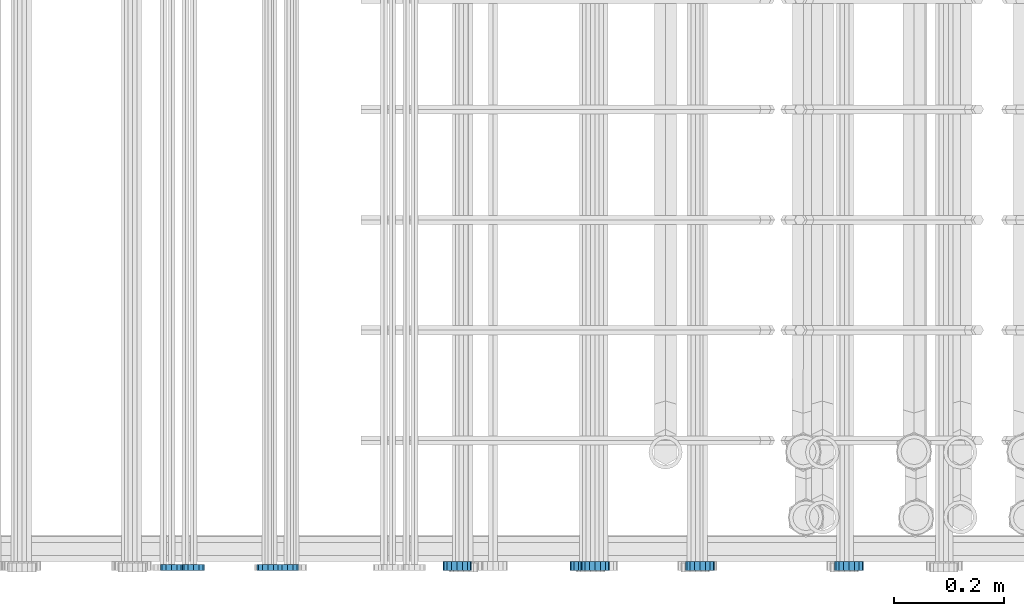
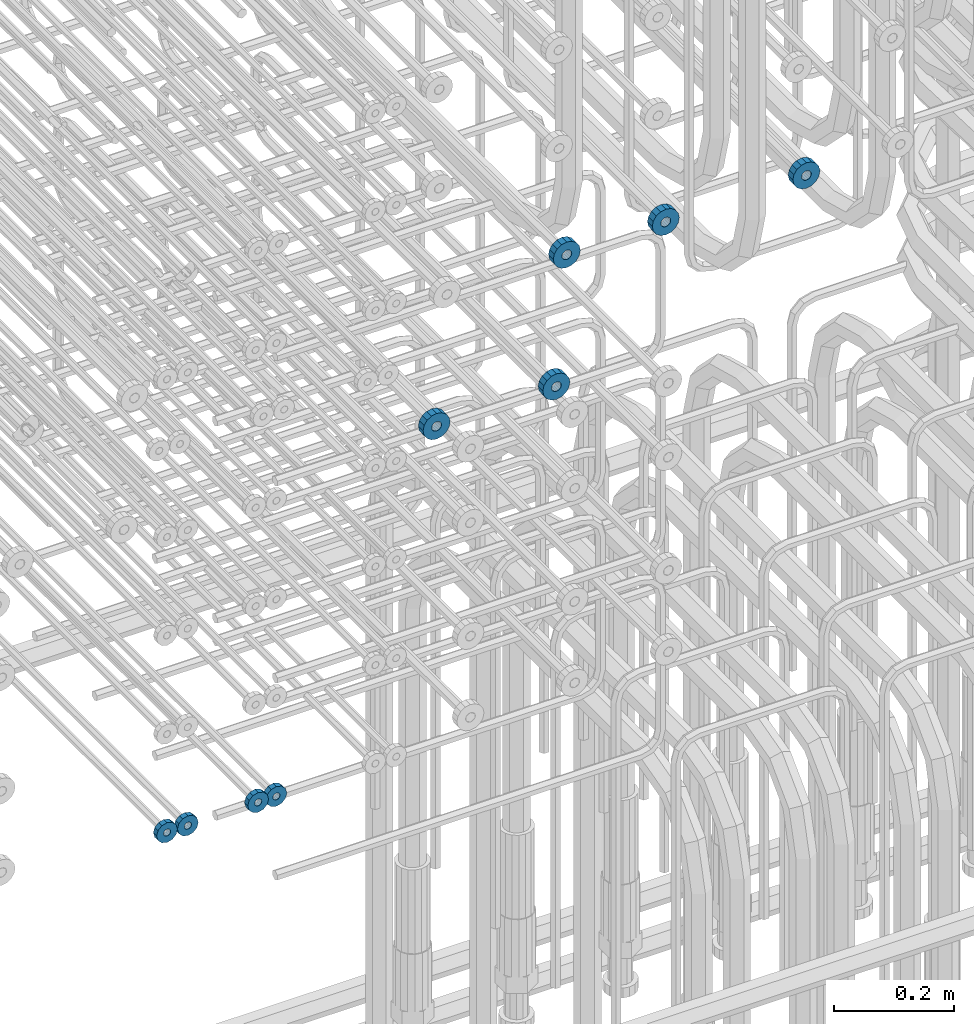
# One storey, part 161 of 177: 9 beams.
"""IFC2X3 building model written with IfcOpenShell, lengths in millimetres."""

from ifc_helpers import new_model, si_unit, frame, origin_with_axes, place, context, subcontext, project, spatial, faceted_brep, material, type_object, element, save


model = new_model("IFC2X3")

# Units and contexts
model_context_1 = context("Model", 3, precision=1e-05, world=origin_with_axes())
model_context_2 = context("Model", 3, precision=1e-05, world=origin_with_axes())
body_context = subcontext(model_context_2, "Body", "Model", "MODEL_VIEW")
ifc_project = project(units=[si_unit("LENGTHUNIT", "METRE", prefix="MILLI"), si_unit("AREAUNIT", "SQUARE_METRE"), si_unit("VOLUMEUNIT", "CUBIC_METRE"), si_unit("MASSUNIT", "GRAM", prefix="KILO"), si_unit("TIMEUNIT", "SECOND"), si_unit("PLANEANGLEUNIT", "RADIAN"), si_unit("SOLIDANGLEUNIT", "STERADIAN"), si_unit("THERMODYNAMICTEMPERATUREUNIT", "DEGREE_CELSIUS"), si_unit("LUMINOUSINTENSITYUNIT", "LUMEN")], contexts=[model_context_1])

# Site, building, storey
site_placement = place(None, origin_with_axes())
site = spatial("IfcSite", under=ifc_project, at=site_placement, CompositionType="ELEMENT")
building_placement = place(site_placement, origin_with_axes())
building = spatial("IfcBuilding", under=site, at=building_placement, Name="Undefined", CompositionType="ELEMENT")
storey_placement = place(building_placement, origin_with_axes())
storey = spatial("IfcBuildingStorey", under=building, at=storey_placement, Name="Undefined", CompositionType="ELEMENT", Elevation=0.0)

# Beams
ifc_material = material(Name="STEEL/Steel_Undefined")
beam_type_1 = type_object("IfcBeamType", PredefinedType="NOTDEFINED")
beam_1_placement = place(storey_placement, frame((2035816.99847313, 6205070.98588034, 20224.9868114202), z_axis=(0.0, 0.0, -1.0), x_axis=(0.0, -1.0, 0.0)))
element("IfcBeam", 1, at=beam_1_placement, inside=storey, type_object=beam_type_1, material=ifc_material, context=body_context, shape_type="Brep", body=[
    faceted_brep([(-3.63797880709171e-12, -7.0, -2.3283064365387e-10), (-8.62348444298797e-13, -6.06217782649107, 3.5), (10.9999999999964, -6.06217782665044, 3.49999999976717), (10.9999999999964, -7.0, -2.3283064365387e-10), (-3.63797880709171e-12, -3.5, 6.06217782618478), (11.0, -3.5, 6.06217782618478), (-1.72469688859759e-12, 0.0, 7.0), (11.0, 0.0, 6.99999999976717), (-3.63797880709171e-12, 3.5, 6.06217782618478), (11.0, 3.5, 6.06217782618478), (-8.62348444298795e-13, 6.06217782649107, 3.5), (10.9999999999964, 6.06217782665044, 3.49999999976717), (-3.63797880709171e-12, 7.0, -2.3283064365387e-10), (10.9999999999964, 7.0, -2.3283064365387e-10), (8.62348444298797e-13, 6.06217782649107, -3.5), (10.9999999999964, 6.06217782665044, -3.50000000023283), (-3.63797880709171e-12, 3.5, -6.06217782665044), (10.9999999999964, 3.5, -6.06217782665044), (1.72469688859759e-12, -2.72004641033163e-15, -7.0), (10.9999999999964, 0.0, -7.00000000023283), (-3.63797880709171e-12, -3.5, -6.06217782665044), (10.9999999999964, -3.5, -6.06217782665044), (8.62348444298796e-13, -6.06217782649107, -3.5), (10.9999999999964, -6.06217782665044, -3.50000000023283), (0.0, -20.0000000009313, 0.0), (0.0, -17.320508075878, -10.0), (10.9999999999964, -17.320508075878, -10.0000000002328), (10.9999999999964, -20.0, -2.3283064365387e-10), (0.0, -10.0000000009313, -17.3205080756452), (11.0, -10.0, -17.320508075878), (0.0, -1.86264514923096e-09, -19.9999999998836), (10.9999999999964, 0.0, -20.0000000002328), (0.0, 9.99999999906868, -17.3205080755288), (11.0, 10.0, -17.320508075878), (0.0, 17.320508075878, -10.0), (10.9999999999964, 17.320508075878, -10.0000000002328), (0.0, 19.9999999990687, 0.0), (10.9999999999964, 20.0, -2.3283064365387e-10), (0.0, 17.3205080740154, 10.0), (11.0, 17.320508075878, 9.99999999976717), (0.0, 9.99999999906868, 17.3205080757616), (10.9999999999964, 10.0, 17.3205080754124), (0.0, 0.0, 20.0000000001164), (10.9999999999964, 0.0, 19.9999999997672), (0.0, -10.0000000009313, 17.3205080757616), (10.9999999999964, -10.0, 17.3205080754124), (0.0, -17.3205080777407, 10.0000000001164), (11.0, -17.320508075878, 9.99999999976717)], [[[0, 1, 2, 3]], [[1, 4, 5, 2]], [[4, 6, 7, 5]], [[6, 8, 9, 7]], [[8, 10, 11, 9]], [[10, 12, 13, 11]], [[12, 14, 15, 13]], [[14, 16, 17, 15]], [[16, 18, 19, 17]], [[18, 20, 21, 19]], [[20, 22, 23, 21]], [[22, 0, 3, 23]], [[24, 25, 26, 27]], [[25, 28, 29, 26]], [[28, 30, 31, 29]], [[30, 32, 33, 31]], [[32, 34, 35, 33]], [[34, 36, 37, 35]], [[36, 38, 39, 37]], [[38, 40, 41, 39]], [[40, 42, 43, 41]], [[42, 44, 45, 43]], [[44, 46, 47, 45]], [[46, 24, 27, 47]], [[29, 31, 33, 35, 37, 39, 41, 43, 45, 47, 27, 26], [5, 7, 9, 11, 13, 15, 17, 19, 21, 23, 3, 2]], [[46, 44, 42, 40, 38, 36, 34, 32, 30, 28, 25, 24], [22, 20, 18, 16, 14, 12, 10, 8, 6, 4, 1, 0]]]),
])
beam_2_placement = place(storey_placement, frame((2035646.99847313, 6205070.98588034, 20224.9868114254), z_axis=(0.0, 0.0, -1.0), x_axis=(0.0, -1.0, 0.0)))
element("IfcBeam", 2, at=beam_2_placement, inside=storey, type_object=beam_type_1, material=ifc_material, context=body_context, shape_type="Brep", body=[
    faceted_brep([(-3.63797880709171e-12, -7.0, -2.3283064365387e-10), (-8.62348444298797e-13, -6.06217782649107, 3.5), (10.9999999999964, -6.06217782665044, 3.49999999976717), (10.9999999999964, -7.0, -2.3283064365387e-10), (-3.63797880709171e-12, -3.5, 6.06217782618478), (11.0, -3.5, 6.06217782618478), (-1.72469688859759e-12, 0.0, 7.0), (11.0, 0.0, 6.99999999976717), (-3.63797880709171e-12, 3.5, 6.06217782618478), (11.0, 3.5, 6.06217782618478), (-8.62348444298795e-13, 6.06217782649107, 3.5), (10.9999999999964, 6.06217782665044, 3.49999999976717), (-3.63797880709171e-12, 7.0, -2.3283064365387e-10), (10.9999999999964, 7.0, -2.3283064365387e-10), (8.62348444298797e-13, 6.06217782649107, -3.5), (10.9999999999964, 6.06217782665044, -3.50000000023283), (-3.63797880709171e-12, 3.5, -6.06217782665044), (10.9999999999964, 3.5, -6.06217782665044), (1.72469688859759e-12, -2.72004641033163e-15, -7.0), (10.9999999999964, 0.0, -7.00000000023283), (-3.63797880709171e-12, -3.5, -6.06217782665044), (10.9999999999964, -3.5, -6.06217782665044), (8.62348444298796e-13, -6.06217782649107, -3.5), (10.9999999999964, -6.06217782665044, -3.50000000023283), (0.0, -20.0000000009313, 0.0), (0.0, -17.320508075878, -10.0), (10.9999999999964, -17.320508075878, -10.0000000002328), (10.9999999999964, -20.0, -2.3283064365387e-10), (0.0, -10.0000000009313, -17.3205080756452), (11.0, -10.0, -17.320508075878), (0.0, -1.86264514923096e-09, -19.9999999998836), (10.9999999999964, 0.0, -20.0000000002328), (0.0, 9.99999999906868, -17.3205080755288), (11.0, 10.0, -17.320508075878), (0.0, 17.320508075878, -10.0), (10.9999999999964, 17.320508075878, -10.0000000002328), (0.0, 19.9999999990687, 0.0), (10.9999999999964, 20.0, -2.3283064365387e-10), (0.0, 17.3205080740154, 10.0), (11.0, 17.320508075878, 9.99999999976717), (0.0, 9.99999999906868, 17.3205080757616), (10.9999999999964, 10.0, 17.3205080754124), (0.0, 0.0, 20.0000000001164), (10.9999999999964, 0.0, 19.9999999997672), (0.0, -10.0000000009313, 17.3205080757616), (10.9999999999964, -10.0, 17.3205080754124), (0.0, -17.3205080777407, 10.0000000001164), (11.0, -17.320508075878, 9.99999999976717)], [[[0, 1, 2, 3]], [[1, 4, 5, 2]], [[4, 6, 7, 5]], [[6, 8, 9, 7]], [[8, 10, 11, 9]], [[10, 12, 13, 11]], [[12, 14, 15, 13]], [[14, 16, 17, 15]], [[16, 18, 19, 17]], [[18, 20, 21, 19]], [[20, 22, 23, 21]], [[22, 0, 3, 23]], [[24, 25, 26, 27]], [[25, 28, 29, 26]], [[28, 30, 31, 29]], [[30, 32, 33, 31]], [[32, 34, 35, 33]], [[34, 36, 37, 35]], [[36, 38, 39, 37]], [[38, 40, 41, 39]], [[40, 42, 43, 41]], [[42, 44, 45, 43]], [[44, 46, 47, 45]], [[46, 24, 27, 47]], [[29, 31, 33, 35, 37, 39, 41, 43, 45, 47, 27, 26], [5, 7, 9, 11, 13, 15, 17, 19, 21, 23, 3, 2]], [[46, 44, 42, 40, 38, 36, 34, 32, 30, 28, 25, 24], [22, 20, 18, 16, 14, 12, 10, 8, 6, 4, 1, 0]]]),
])
beam_3_placement = place(storey_placement, frame((2035781.99847313, 6205070.98588034, 20224.9868114202), z_axis=(0.0, 0.0, -1.0), x_axis=(0.0, -1.0, 0.0)))
element("IfcBeam", 3, at=beam_3_placement, inside=storey, type_object=beam_type_1, material=ifc_material, context=body_context, shape_type="Brep", body=[
    faceted_brep([(-3.63797880709171e-12, -7.0, -2.3283064365387e-10), (-8.62348444298797e-13, -6.06217782649107, 3.5), (10.9999999999964, -6.06217782665044, 3.49999999976717), (10.9999999999964, -7.0, -2.3283064365387e-10), (-3.63797880709171e-12, -3.5, 6.06217782618478), (11.0, -3.5, 6.06217782618478), (-1.72469688859759e-12, 0.0, 7.0), (11.0, 0.0, 6.99999999976717), (-3.63797880709171e-12, 3.5, 6.06217782618478), (11.0, 3.5, 6.06217782618478), (-8.62348444298795e-13, 6.06217782649107, 3.5), (10.9999999999964, 6.06217782665044, 3.49999999976717), (-3.63797880709171e-12, 7.0, -2.3283064365387e-10), (10.9999999999964, 7.0, -2.3283064365387e-10), (8.62348444298797e-13, 6.06217782649107, -3.5), (10.9999999999964, 6.06217782665044, -3.50000000023283), (-3.63797880709171e-12, 3.5, -6.06217782665044), (10.9999999999964, 3.5, -6.06217782665044), (1.72469688859759e-12, -2.72004641033163e-15, -7.0), (10.9999999999964, 0.0, -7.00000000023283), (-3.63797880709171e-12, -3.5, -6.06217782665044), (10.9999999999964, -3.5, -6.06217782665044), (8.62348444298796e-13, -6.06217782649107, -3.5), (10.9999999999964, -6.06217782665044, -3.50000000023283), (0.0, -20.0000000009313, 0.0), (0.0, -17.320508075878, -10.0), (10.9999999999964, -17.320508075878, -10.0000000002328), (10.9999999999964, -20.0, -2.3283064365387e-10), (0.0, -10.0000000009313, -17.3205080756452), (11.0, -10.0, -17.320508075878), (0.0, -1.86264514923096e-09, -19.9999999998836), (10.9999999999964, 0.0, -20.0000000002328), (0.0, 9.99999999906868, -17.3205080755288), (11.0, 10.0, -17.320508075878), (0.0, 17.320508075878, -10.0), (10.9999999999964, 17.320508075878, -10.0000000002328), (0.0, 19.9999999990687, 0.0), (10.9999999999964, 20.0, -2.3283064365387e-10), (0.0, 17.3205080740154, 10.0), (11.0, 17.320508075878, 9.99999999976717), (0.0, 9.99999999906868, 17.3205080757616), (10.9999999999964, 10.0, 17.3205080754124), (0.0, 0.0, 20.0000000001164), (10.9999999999964, 0.0, 19.9999999997672), (0.0, -10.0000000009313, 17.3205080757616), (10.9999999999964, -10.0, 17.3205080754124), (0.0, -17.3205080777407, 10.0000000001164), (11.0, -17.320508075878, 9.99999999976717)], [[[0, 1, 2, 3]], [[1, 4, 5, 2]], [[4, 6, 7, 5]], [[6, 8, 9, 7]], [[8, 10, 11, 9]], [[10, 12, 13, 11]], [[12, 14, 15, 13]], [[14, 16, 17, 15]], [[16, 18, 19, 17]], [[18, 20, 21, 19]], [[20, 22, 23, 21]], [[22, 0, 3, 23]], [[24, 25, 26, 27]], [[25, 28, 29, 26]], [[28, 30, 31, 29]], [[30, 32, 33, 31]], [[32, 34, 35, 33]], [[34, 36, 37, 35]], [[36, 38, 39, 37]], [[38, 40, 41, 39]], [[40, 42, 43, 41]], [[42, 44, 45, 43]], [[44, 46, 47, 45]], [[46, 24, 27, 47]], [[29, 31, 33, 35, 37, 39, 41, 43, 45, 47, 27, 26], [5, 7, 9, 11, 13, 15, 17, 19, 21, 23, 3, 2]], [[46, 44, 42, 40, 38, 36, 34, 32, 30, 28, 25, 24], [22, 20, 18, 16, 14, 12, 10, 8, 6, 4, 1, 0]]]),
])
beam_4_placement = place(storey_placement, frame((2035606.99847313, 6205070.98588034, 20224.9868114254), z_axis=(0.0, 0.0, -1.0), x_axis=(0.0, -1.0, 0.0)))
element("IfcBeam", 4, at=beam_4_placement, inside=storey, type_object=beam_type_1, material=ifc_material, context=body_context, shape_type="Brep", body=[
    faceted_brep([(-3.63797880709171e-12, -7.0, -2.3283064365387e-10), (-8.62348444298797e-13, -6.06217782649107, 3.5), (10.9999999999964, -6.06217782665044, 3.49999999976717), (10.9999999999964, -7.0, -2.3283064365387e-10), (-3.63797880709171e-12, -3.5, 6.06217782618478), (11.0, -3.5, 6.06217782618478), (-1.72469688859759e-12, 0.0, 7.0), (11.0, 0.0, 6.99999999976717), (-3.63797880709171e-12, 3.5, 6.06217782618478), (11.0, 3.5, 6.06217782618478), (-8.62348444298795e-13, 6.06217782649107, 3.5), (10.9999999999964, 6.06217782665044, 3.49999999976717), (-3.63797880709171e-12, 7.0, -2.3283064365387e-10), (10.9999999999964, 7.0, -2.3283064365387e-10), (8.62348444298797e-13, 6.06217782649107, -3.5), (10.9999999999964, 6.06217782665044, -3.50000000023283), (-3.63797880709171e-12, 3.5, -6.06217782665044), (10.9999999999964, 3.5, -6.06217782665044), (1.72469688859759e-12, -2.72004641033163e-15, -7.0), (10.9999999999964, 0.0, -7.00000000023283), (-3.63797880709171e-12, -3.5, -6.06217782665044), (10.9999999999964, -3.5, -6.06217782665044), (8.62348444298796e-13, -6.06217782649107, -3.5), (10.9999999999964, -6.06217782665044, -3.50000000023283), (0.0, -20.0000000009313, 0.0), (0.0, -17.320508075878, -10.0), (10.9999999999964, -17.320508075878, -10.0000000002328), (10.9999999999964, -20.0, -2.3283064365387e-10), (0.0, -10.0000000009313, -17.3205080756452), (11.0, -10.0, -17.320508075878), (0.0, -1.86264514923096e-09, -19.9999999998836), (10.9999999999964, 0.0, -20.0000000002328), (0.0, 9.99999999906868, -17.3205080755288), (11.0, 10.0, -17.320508075878), (0.0, 17.320508075878, -10.0), (10.9999999999964, 17.320508075878, -10.0000000002328), (0.0, 19.9999999990687, 0.0), (10.9999999999964, 20.0, -2.3283064365387e-10), (0.0, 17.3205080740154, 10.0), (11.0, 17.320508075878, 9.99999999976717), (0.0, 9.99999999906868, 17.3205080757616), (10.9999999999964, 10.0, 17.3205080754124), (0.0, 0.0, 20.0000000001164), (10.9999999999964, 0.0, 19.9999999997672), (0.0, -10.0000000009313, 17.3205080757616), (10.9999999999964, -10.0, 17.3205080754124), (0.0, -17.3205080777407, 10.0000000001164), (11.0, -17.320508075878, 9.99999999976717)], [[[0, 1, 2, 3]], [[1, 4, 5, 2]], [[4, 6, 7, 5]], [[6, 8, 9, 7]], [[8, 10, 11, 9]], [[10, 12, 13, 11]], [[12, 14, 15, 13]], [[14, 16, 17, 15]], [[16, 18, 19, 17]], [[18, 20, 21, 19]], [[20, 22, 23, 21]], [[22, 0, 3, 23]], [[24, 25, 26, 27]], [[25, 28, 29, 26]], [[28, 30, 31, 29]], [[30, 32, 33, 31]], [[32, 34, 35, 33]], [[34, 36, 37, 35]], [[36, 38, 39, 37]], [[38, 40, 41, 39]], [[40, 42, 43, 41]], [[42, 44, 45, 43]], [[44, 46, 47, 45]], [[46, 24, 27, 47]], [[29, 31, 33, 35, 37, 39, 41, 43, 45, 47, 27, 26], [5, 7, 9, 11, 13, 15, 17, 19, 21, 23, 3, 2]], [[46, 44, 42, 40, 38, 36, 34, 32, 30, 28, 25, 24], [22, 20, 18, 16, 14, 12, 10, 8, 6, 4, 1, 0]]]),
])
beam_type_2 = type_object("IfcBeamType", PredefinedType="NOTDEFINED")
beam_5_placement = place(storey_placement, frame((2036354.49847313, 6205075.98588568, 20868.486812475), z_axis=(0.0, 0.0, -1.0), x_axis=(0.0, -1.0, 0.0)))
element("IfcBeam", 5, at=beam_5_placement, inside=storey, type_object=beam_type_2, material=ifc_material, context=body_context, shape_type="Brep", body=[
    faceted_brep([(0.0, -9.5, 0.0), (0.0, -8.77685555908829, 3.63549260746731), (16.0, -8.77685555908829, 3.63549260746731), (16.0, -9.5, 0.0), (0.0, -6.71751442085952, 6.71751442127061), (16.0, -6.71751442085952, 6.71751442127061), (0.0, -3.63549260701984, 8.77685555885546), (16.0, -3.63549260701984, 8.77685555885546), (-2.02452244836415e-12, 0.0, 9.5), (16.0, 0.0, 9.5), (0.0, 3.63549260701984, 8.77685555885546), (16.0, 3.63549260701984, 8.77685555885546), (0.0, 6.71751442085952, 6.71751442127061), (16.0, 6.71751442085952, 6.71751442127061), (0.0, 8.77685555908829, 3.63549260746731), (16.0, 8.77685555908829, 3.63549260746731), (0.0, 9.5, 0.0), (16.0, 9.5, 0.0), (0.0, 8.77685555908829, -3.63549260746731), (16.0, 8.77685555908829, -3.63549260746731), (0.0, 6.71751442085952, -6.71751442127061), (16.0, 6.71751442085952, -6.71751442127061), (0.0, 3.63549260701984, -8.77685555885546), (16.0, 3.63549260701984, -8.77685555885546), (2.02452244836415e-12, -3.69149155687865e-15, -9.5), (16.0, 0.0, -9.5), (0.0, -3.63549260701984, -8.77685555885546), (16.0, -3.63549260701984, -8.77685555885546), (0.0, -6.71751442085952, -6.71751442127061), (16.0, -6.71751442085952, -6.71751442127061), (0.0, -8.77685555908829, -3.63549260746731), (16.0, -8.77685555908829, -3.63549260746731), (0.0, -26.0, 0.0), (0.0, -24.0208678450435, -9.94976924149159), (16.0, -24.0208678450435, -9.94976924149159), (16.0, -26.0, 0.0), (0.0, -18.3847763109952, -18.3847763108497), (16.0, -18.3847763109952, -18.3847763108497), (0.0, -9.94976924173534, -24.0208678452946), (16.0, -9.94976924173534, -24.0208678452946), (0.0, 0.0, -26.0), (16.0, 0.0, -26.0), (0.0, 9.94976924173534, -24.0208678452946), (16.0, 9.94976924173534, -24.0208678452946), (0.0, 18.3847763109952, -18.3847763108497), (16.0, 18.3847763109952, -18.3847763108497), (0.0, 24.0208678450435, -9.94976924149159), (16.0, 24.0208678450435, -9.94976924149159), (0.0, 26.0, 0.0), (16.0, 26.0, 0.0), (0.0, 24.0208678450435, 9.94976924149159), (16.0, 24.0208678450435, 9.94976924149159), (0.0, 18.3847763109952, 18.3847763108497), (16.0, 18.3847763109952, 18.3847763108497), (0.0, 9.94976924173534, 24.0208678452946), (16.0, 9.94976924173534, 24.0208678452946), (0.0, 0.0, 26.0), (16.0, 0.0, 26.0), (0.0, -9.94976924173534, 24.0208678452946), (16.0, -9.94976924173534, 24.0208678452946), (0.0, -18.3847763109952, 18.3847763108497), (16.0, -18.3847763109952, 18.3847763108497), (0.0, -24.0208678450435, 9.94976924149159), (16.0, -24.0208678450435, 9.94976924149159)], [[[0, 1, 2, 3]], [[1, 4, 5, 2]], [[4, 6, 7, 5]], [[6, 8, 9, 7]], [[8, 10, 11, 9]], [[10, 12, 13, 11]], [[12, 14, 15, 13]], [[14, 16, 17, 15]], [[16, 18, 19, 17]], [[18, 20, 21, 19]], [[20, 22, 23, 21]], [[22, 24, 25, 23]], [[24, 26, 27, 25]], [[26, 28, 29, 27]], [[28, 30, 31, 29]], [[30, 0, 3, 31]], [[32, 33, 34, 35]], [[33, 36, 37, 34]], [[36, 38, 39, 37]], [[38, 40, 41, 39]], [[40, 42, 43, 41]], [[42, 44, 45, 43]], [[44, 46, 47, 45]], [[46, 48, 49, 47]], [[48, 50, 51, 49]], [[50, 52, 53, 51]], [[52, 54, 55, 53]], [[54, 56, 57, 55]], [[56, 58, 59, 57]], [[58, 60, 61, 59]], [[60, 62, 63, 61]], [[62, 32, 35, 63]], [[37, 39, 41, 43, 45, 47, 49, 51, 53, 55, 57, 59, 61, 63, 35, 34], [5, 7, 9, 11, 13, 15, 17, 19, 21, 23, 25, 27, 29, 31, 3, 2]], [[62, 60, 58, 56, 54, 52, 50, 48, 46, 44, 42, 40, 38, 36, 33, 32], [30, 28, 26, 24, 22, 20, 18, 16, 14, 12, 10, 8, 6, 4, 1, 0]]]),
])
beam_6_placement = place(storey_placement, frame((2036124.49847313, 6205075.98588568, 20868.486812475), z_axis=(0.0, 0.0, -1.0), x_axis=(0.0, -1.0, 0.0)))
element("IfcBeam", 6, at=beam_6_placement, inside=storey, type_object=beam_type_2, material=ifc_material, context=body_context, shape_type="Brep", body=[
    faceted_brep([(0.0, -9.5, 0.0), (0.0, -8.77685555908829, 3.63549260746731), (16.0, -8.77685555908829, 3.63549260746731), (16.0, -9.5, 0.0), (0.0, -6.71751442085952, 6.71751442127061), (16.0, -6.71751442085952, 6.71751442127061), (0.0, -3.63549260701984, 8.77685555885546), (16.0, -3.63549260701984, 8.77685555885546), (-2.02452244836415e-12, 0.0, 9.5), (16.0, 0.0, 9.5), (0.0, 3.63549260701984, 8.77685555885546), (16.0, 3.63549260701984, 8.77685555885546), (0.0, 6.71751442085952, 6.71751442127061), (16.0, 6.71751442085952, 6.71751442127061), (0.0, 8.77685555908829, 3.63549260746731), (16.0, 8.77685555908829, 3.63549260746731), (0.0, 9.5, 0.0), (16.0, 9.5, 0.0), (0.0, 8.77685555908829, -3.63549260746731), (16.0, 8.77685555908829, -3.63549260746731), (0.0, 6.71751442085952, -6.71751442127061), (16.0, 6.71751442085952, -6.71751442127061), (0.0, 3.63549260701984, -8.77685555885546), (16.0, 3.63549260701984, -8.77685555885546), (2.02452244836415e-12, -3.69149155687865e-15, -9.5), (16.0, 0.0, -9.5), (0.0, -3.63549260701984, -8.77685555885546), (16.0, -3.63549260701984, -8.77685555885546), (0.0, -6.71751442085952, -6.71751442127061), (16.0, -6.71751442085952, -6.71751442127061), (0.0, -8.77685555908829, -3.63549260746731), (16.0, -8.77685555908829, -3.63549260746731), (0.0, -26.0, 0.0), (0.0, -24.0208678450435, -9.94976924149159), (16.0, -24.0208678450435, -9.94976924149159), (16.0, -26.0, 0.0), (0.0, -18.3847763109952, -18.3847763108497), (16.0, -18.3847763109952, -18.3847763108497), (0.0, -9.94976924173534, -24.0208678452946), (16.0, -9.94976924173534, -24.0208678452946), (0.0, 0.0, -26.0), (16.0, 0.0, -26.0), (0.0, 9.94976924173534, -24.0208678452946), (16.0, 9.94976924173534, -24.0208678452946), (0.0, 18.3847763109952, -18.3847763108497), (16.0, 18.3847763109952, -18.3847763108497), (0.0, 24.0208678450435, -9.94976924149159), (16.0, 24.0208678450435, -9.94976924149159), (0.0, 26.0, 0.0), (16.0, 26.0, 0.0), (0.0, 24.0208678450435, 9.94976924149159), (16.0, 24.0208678450435, 9.94976924149159), (0.0, 18.3847763109952, 18.3847763108497), (16.0, 18.3847763109952, 18.3847763108497), (0.0, 9.94976924173534, 24.0208678452946), (16.0, 9.94976924173534, 24.0208678452946), (0.0, 0.0, 26.0), (16.0, 0.0, 26.0), (0.0, -9.94976924173534, 24.0208678452946), (16.0, -9.94976924173534, 24.0208678452946), (0.0, -18.3847763109952, 18.3847763108497), (16.0, -18.3847763109952, 18.3847763108497), (0.0, -24.0208678450435, 9.94976924149159), (16.0, -24.0208678450435, 9.94976924149159)], [[[0, 1, 2, 3]], [[1, 4, 5, 2]], [[4, 6, 7, 5]], [[6, 8, 9, 7]], [[8, 10, 11, 9]], [[10, 12, 13, 11]], [[12, 14, 15, 13]], [[14, 16, 17, 15]], [[16, 18, 19, 17]], [[18, 20, 21, 19]], [[20, 22, 23, 21]], [[22, 24, 25, 23]], [[24, 26, 27, 25]], [[26, 28, 29, 27]], [[28, 30, 31, 29]], [[30, 0, 3, 31]], [[32, 33, 34, 35]], [[33, 36, 37, 34]], [[36, 38, 39, 37]], [[38, 40, 41, 39]], [[40, 42, 43, 41]], [[42, 44, 45, 43]], [[44, 46, 47, 45]], [[46, 48, 49, 47]], [[48, 50, 51, 49]], [[50, 52, 53, 51]], [[52, 54, 55, 53]], [[54, 56, 57, 55]], [[56, 58, 59, 57]], [[58, 60, 61, 59]], [[60, 62, 63, 61]], [[62, 32, 35, 63]], [[37, 39, 41, 43, 45, 47, 49, 51, 53, 55, 57, 59, 61, 63, 35, 34], [5, 7, 9, 11, 13, 15, 17, 19, 21, 23, 25, 27, 29, 31, 3, 2]], [[62, 60, 58, 56, 54, 52, 50, 48, 46, 44, 42, 40, 38, 36, 33, 32], [30, 28, 26, 24, 22, 20, 18, 16, 14, 12, 10, 8, 6, 4, 1, 0]]]),
])
beam_7_placement = place(storey_placement, frame((2036834.49847313, 6205075.98588578, 21128.9868125734), z_axis=(0.0, 0.0, -1.0), x_axis=(0.0, -1.0, 0.0)))
element("IfcBeam", 7, at=beam_7_placement, inside=storey, type_object=beam_type_2, material=ifc_material, context=body_context, shape_type="Brep", body=[
    faceted_brep([(0.0, -9.5, 0.0), (0.0, -8.77685555908829, 3.63549260746731), (16.0, -8.77685555908829, 3.63549260746731), (16.0, -9.5, 0.0), (0.0, -6.71751442085952, 6.71751442127061), (16.0, -6.71751442085952, 6.71751442127061), (0.0, -3.63549260701984, 8.77685555885546), (16.0, -3.63549260701984, 8.77685555885546), (-2.02452244836415e-12, 0.0, 9.5), (16.0, 0.0, 9.5), (0.0, 3.63549260701984, 8.77685555885546), (16.0, 3.63549260701984, 8.77685555885546), (0.0, 6.71751442085952, 6.71751442127061), (16.0, 6.71751442085952, 6.71751442127061), (0.0, 8.77685555908829, 3.63549260746731), (16.0, 8.77685555908829, 3.63549260746731), (0.0, 9.5, 0.0), (16.0, 9.5, 0.0), (0.0, 8.77685555908829, -3.63549260746731), (16.0, 8.77685555908829, -3.63549260746731), (0.0, 6.71751442085952, -6.71751442127061), (16.0, 6.71751442085952, -6.71751442127061), (0.0, 3.63549260701984, -8.77685555885546), (16.0, 3.63549260701984, -8.77685555885546), (2.02452244836415e-12, -3.69149155687865e-15, -9.5), (16.0, 0.0, -9.5), (0.0, -3.63549260701984, -8.77685555885546), (16.0, -3.63549260701984, -8.77685555885546), (0.0, -6.71751442085952, -6.71751442127061), (16.0, -6.71751442085952, -6.71751442127061), (0.0, -8.77685555908829, -3.63549260746731), (16.0, -8.77685555908829, -3.63549260746731), (0.0, -26.0, 0.0), (0.0, -24.0208678450435, -9.94976924149159), (16.0, -24.0208678450435, -9.94976924149159), (16.0, -26.0, 0.0), (0.0, -18.3847763109952, -18.3847763108497), (16.0, -18.3847763109952, -18.3847763108497), (0.0, -9.94976924173534, -24.0208678452946), (16.0, -9.94976924173534, -24.0208678452946), (0.0, 0.0, -26.0), (16.0, 0.0, -26.0), (0.0, 9.94976924173534, -24.0208678452946), (16.0, 9.94976924173534, -24.0208678452946), (0.0, 18.3847763109952, -18.3847763108497), (16.0, 18.3847763109952, -18.3847763108497), (0.0, 24.0208678450435, -9.94976924149159), (16.0, 24.0208678450435, -9.94976924149159), (0.0, 26.0, 0.0), (16.0, 26.0, 0.0), (0.0, 24.0208678450435, 9.94976924149159), (16.0, 24.0208678450435, 9.94976924149159), (0.0, 18.3847763109952, 18.3847763108497), (16.0, 18.3847763109952, 18.3847763108497), (0.0, 9.94976924173534, 24.0208678452946), (16.0, 9.94976924173534, 24.0208678452946), (0.0, 0.0, 26.0), (16.0, 0.0, 26.0), (0.0, -9.94976924173534, 24.0208678452946), (16.0, -9.94976924173534, 24.0208678452946), (0.0, -18.3847763109952, 18.3847763108497), (16.0, -18.3847763109952, 18.3847763108497), (0.0, -24.0208678450435, 9.94976924149159), (16.0, -24.0208678450435, 9.94976924149159)], [[[0, 1, 2, 3]], [[1, 4, 5, 2]], [[4, 6, 7, 5]], [[6, 8, 9, 7]], [[8, 10, 11, 9]], [[10, 12, 13, 11]], [[12, 14, 15, 13]], [[14, 16, 17, 15]], [[16, 18, 19, 17]], [[18, 20, 21, 19]], [[20, 22, 23, 21]], [[22, 24, 25, 23]], [[24, 26, 27, 25]], [[26, 28, 29, 27]], [[28, 30, 31, 29]], [[30, 0, 3, 31]], [[32, 33, 34, 35]], [[33, 36, 37, 34]], [[36, 38, 39, 37]], [[38, 40, 41, 39]], [[40, 42, 43, 41]], [[42, 44, 45, 43]], [[44, 46, 47, 45]], [[46, 48, 49, 47]], [[48, 50, 51, 49]], [[50, 52, 53, 51]], [[52, 54, 55, 53]], [[54, 56, 57, 55]], [[56, 58, 59, 57]], [[58, 60, 61, 59]], [[60, 62, 63, 61]], [[62, 32, 35, 63]], [[37, 39, 41, 43, 45, 47, 49, 51, 53, 55, 57, 59, 61, 63, 35, 34], [5, 7, 9, 11, 13, 15, 17, 19, 21, 23, 25, 27, 29, 31, 3, 2]], [[62, 60, 58, 56, 54, 52, 50, 48, 46, 44, 42, 40, 38, 36, 33, 32], [30, 28, 26, 24, 22, 20, 18, 16, 14, 12, 10, 8, 6, 4, 1, 0]]]),
])
beam_8_placement = place(storey_placement, frame((2036564.49847313, 6205075.98588578, 21128.9868125735), z_axis=(0.0, 0.0, -1.0), x_axis=(0.0, -1.0, 0.0)))
element("IfcBeam", 8, at=beam_8_placement, inside=storey, type_object=beam_type_2, material=ifc_material, context=body_context, shape_type="Brep", body=[
    faceted_brep([(0.0, -9.5, 0.0), (0.0, -8.77685555908829, 3.63549260746731), (16.0, -8.77685555908829, 3.63549260746731), (16.0, -9.5, 0.0), (0.0, -6.71751442085952, 6.71751442127061), (16.0, -6.71751442085952, 6.71751442127061), (0.0, -3.63549260701984, 8.77685555885546), (16.0, -3.63549260701984, 8.77685555885546), (-2.02452244836415e-12, 0.0, 9.5), (16.0, 0.0, 9.5), (0.0, 3.63549260701984, 8.77685555885546), (16.0, 3.63549260701984, 8.77685555885546), (0.0, 6.71751442085952, 6.71751442127061), (16.0, 6.71751442085952, 6.71751442127061), (0.0, 8.77685555908829, 3.63549260746731), (16.0, 8.77685555908829, 3.63549260746731), (0.0, 9.5, 0.0), (16.0, 9.5, 0.0), (0.0, 8.77685555908829, -3.63549260746731), (16.0, 8.77685555908829, -3.63549260746731), (0.0, 6.71751442085952, -6.71751442127061), (16.0, 6.71751442085952, -6.71751442127061), (0.0, 3.63549260701984, -8.77685555885546), (16.0, 3.63549260701984, -8.77685555885546), (2.02452244836415e-12, -3.69149155687865e-15, -9.5), (16.0, 0.0, -9.5), (0.0, -3.63549260701984, -8.77685555885546), (16.0, -3.63549260701984, -8.77685555885546), (0.0, -6.71751442085952, -6.71751442127061), (16.0, -6.71751442085952, -6.71751442127061), (0.0, -8.77685555908829, -3.63549260746731), (16.0, -8.77685555908829, -3.63549260746731), (0.0, -26.0, 0.0), (0.0, -24.0208678450435, -9.94976924149159), (16.0, -24.0208678450435, -9.94976924149159), (16.0, -26.0, 0.0), (0.0, -18.3847763109952, -18.3847763108497), (16.0, -18.3847763109952, -18.3847763108497), (0.0, -9.94976924173534, -24.0208678452946), (16.0, -9.94976924173534, -24.0208678452946), (0.0, 0.0, -26.0), (16.0, 0.0, -26.0), (0.0, 9.94976924173534, -24.0208678452946), (16.0, 9.94976924173534, -24.0208678452946), (0.0, 18.3847763109952, -18.3847763108497), (16.0, 18.3847763109952, -18.3847763108497), (0.0, 24.0208678450435, -9.94976924149159), (16.0, 24.0208678450435, -9.94976924149159), (0.0, 26.0, 0.0), (16.0, 26.0, 0.0), (0.0, 24.0208678450435, 9.94976924149159), (16.0, 24.0208678450435, 9.94976924149159), (0.0, 18.3847763109952, 18.3847763108497), (16.0, 18.3847763109952, 18.3847763108497), (0.0, 9.94976924173534, 24.0208678452946), (16.0, 9.94976924173534, 24.0208678452946), (0.0, 0.0, 26.0), (16.0, 0.0, 26.0), (0.0, -9.94976924173534, 24.0208678452946), (16.0, -9.94976924173534, 24.0208678452946), (0.0, -18.3847763109952, 18.3847763108497), (16.0, -18.3847763109952, 18.3847763108497), (0.0, -24.0208678450435, 9.94976924149159), (16.0, -24.0208678450435, 9.94976924149159)], [[[0, 1, 2, 3]], [[1, 4, 5, 2]], [[4, 6, 7, 5]], [[6, 8, 9, 7]], [[8, 10, 11, 9]], [[10, 12, 13, 11]], [[12, 14, 15, 13]], [[14, 16, 17, 15]], [[16, 18, 19, 17]], [[18, 20, 21, 19]], [[20, 22, 23, 21]], [[22, 24, 25, 23]], [[24, 26, 27, 25]], [[26, 28, 29, 27]], [[28, 30, 31, 29]], [[30, 0, 3, 31]], [[32, 33, 34, 35]], [[33, 36, 37, 34]], [[36, 38, 39, 37]], [[38, 40, 41, 39]], [[40, 42, 43, 41]], [[42, 44, 45, 43]], [[44, 46, 47, 45]], [[46, 48, 49, 47]], [[48, 50, 51, 49]], [[50, 52, 53, 51]], [[52, 54, 55, 53]], [[54, 56, 57, 55]], [[56, 58, 59, 57]], [[58, 60, 61, 59]], [[60, 62, 63, 61]], [[62, 32, 35, 63]], [[37, 39, 41, 43, 45, 47, 49, 51, 53, 55, 57, 59, 61, 63, 35, 34], [5, 7, 9, 11, 13, 15, 17, 19, 21, 23, 25, 27, 29, 31, 3, 2]], [[62, 60, 58, 56, 54, 52, 50, 48, 46, 44, 42, 40, 38, 36, 33, 32], [30, 28, 26, 24, 22, 20, 18, 16, 14, 12, 10, 8, 6, 4, 1, 0]]]),
])
beam_9_placement = place(storey_placement, frame((2036374.49847313, 6205075.98588578, 21128.9868125735), z_axis=(0.0, 0.0, -1.0), x_axis=(0.0, -1.0, 0.0)))
element("IfcBeam", 9, at=beam_9_placement, inside=storey, type_object=beam_type_2, material=ifc_material, context=body_context, shape_type="Brep", body=[
    faceted_brep([(0.0, -9.5, 0.0), (0.0, -8.77685555908829, 3.63549260746731), (16.0, -8.77685555908829, 3.63549260746731), (16.0, -9.5, 0.0), (0.0, -6.71751442085952, 6.71751442127061), (16.0, -6.71751442085952, 6.71751442127061), (0.0, -3.63549260701984, 8.77685555885546), (16.0, -3.63549260701984, 8.77685555885546), (-2.02452244836415e-12, 0.0, 9.5), (16.0, 0.0, 9.5), (0.0, 3.63549260701984, 8.77685555885546), (16.0, 3.63549260701984, 8.77685555885546), (0.0, 6.71751442085952, 6.71751442127061), (16.0, 6.71751442085952, 6.71751442127061), (0.0, 8.77685555908829, 3.63549260746731), (16.0, 8.77685555908829, 3.63549260746731), (0.0, 9.5, 0.0), (16.0, 9.5, 0.0), (0.0, 8.77685555908829, -3.63549260746731), (16.0, 8.77685555908829, -3.63549260746731), (0.0, 6.71751442085952, -6.71751442127061), (16.0, 6.71751442085952, -6.71751442127061), (0.0, 3.63549260701984, -8.77685555885546), (16.0, 3.63549260701984, -8.77685555885546), (2.02452244836415e-12, -3.69149155687865e-15, -9.5), (16.0, 0.0, -9.5), (0.0, -3.63549260701984, -8.77685555885546), (16.0, -3.63549260701984, -8.77685555885546), (0.0, -6.71751442085952, -6.71751442127061), (16.0, -6.71751442085952, -6.71751442127061), (0.0, -8.77685555908829, -3.63549260746731), (16.0, -8.77685555908829, -3.63549260746731), (0.0, -26.0, 0.0), (0.0, -24.0208678450435, -9.94976924149159), (16.0, -24.0208678450435, -9.94976924149159), (16.0, -26.0, 0.0), (0.0, -18.3847763109952, -18.3847763108497), (16.0, -18.3847763109952, -18.3847763108497), (0.0, -9.94976924173534, -24.0208678452946), (16.0, -9.94976924173534, -24.0208678452946), (0.0, 0.0, -26.0), (16.0, 0.0, -26.0), (0.0, 9.94976924173534, -24.0208678452946), (16.0, 9.94976924173534, -24.0208678452946), (0.0, 18.3847763109952, -18.3847763108497), (16.0, 18.3847763109952, -18.3847763108497), (0.0, 24.0208678450435, -9.94976924149159), (16.0, 24.0208678450435, -9.94976924149159), (0.0, 26.0, 0.0), (16.0, 26.0, 0.0), (0.0, 24.0208678450435, 9.94976924149159), (16.0, 24.0208678450435, 9.94976924149159), (0.0, 18.3847763109952, 18.3847763108497), (16.0, 18.3847763109952, 18.3847763108497), (0.0, 9.94976924173534, 24.0208678452946), (16.0, 9.94976924173534, 24.0208678452946), (0.0, 0.0, 26.0), (16.0, 0.0, 26.0), (0.0, -9.94976924173534, 24.0208678452946), (16.0, -9.94976924173534, 24.0208678452946), (0.0, -18.3847763109952, 18.3847763108497), (16.0, -18.3847763109952, 18.3847763108497), (0.0, -24.0208678450435, 9.94976924149159), (16.0, -24.0208678450435, 9.94976924149159)], [[[0, 1, 2, 3]], [[1, 4, 5, 2]], [[4, 6, 7, 5]], [[6, 8, 9, 7]], [[8, 10, 11, 9]], [[10, 12, 13, 11]], [[12, 14, 15, 13]], [[14, 16, 17, 15]], [[16, 18, 19, 17]], [[18, 20, 21, 19]], [[20, 22, 23, 21]], [[22, 24, 25, 23]], [[24, 26, 27, 25]], [[26, 28, 29, 27]], [[28, 30, 31, 29]], [[30, 0, 3, 31]], [[32, 33, 34, 35]], [[33, 36, 37, 34]], [[36, 38, 39, 37]], [[38, 40, 41, 39]], [[40, 42, 43, 41]], [[42, 44, 45, 43]], [[44, 46, 47, 45]], [[46, 48, 49, 47]], [[48, 50, 51, 49]], [[50, 52, 53, 51]], [[52, 54, 55, 53]], [[54, 56, 57, 55]], [[56, 58, 59, 57]], [[58, 60, 61, 59]], [[60, 62, 63, 61]], [[62, 32, 35, 63]], [[37, 39, 41, 43, 45, 47, 49, 51, 53, 55, 57, 59, 61, 63, 35, 34], [5, 7, 9, 11, 13, 15, 17, 19, 21, 23, 25, 27, 29, 31, 3, 2]], [[62, 60, 58, 56, 54, 52, 50, 48, 46, 44, 42, 40, 38, 36, 33, 32], [30, 28, 26, 24, 22, 20, 18, 16, 14, 12, 10, 8, 6, 4, 1, 0]]]),
])

save(model, "model.ifc")
